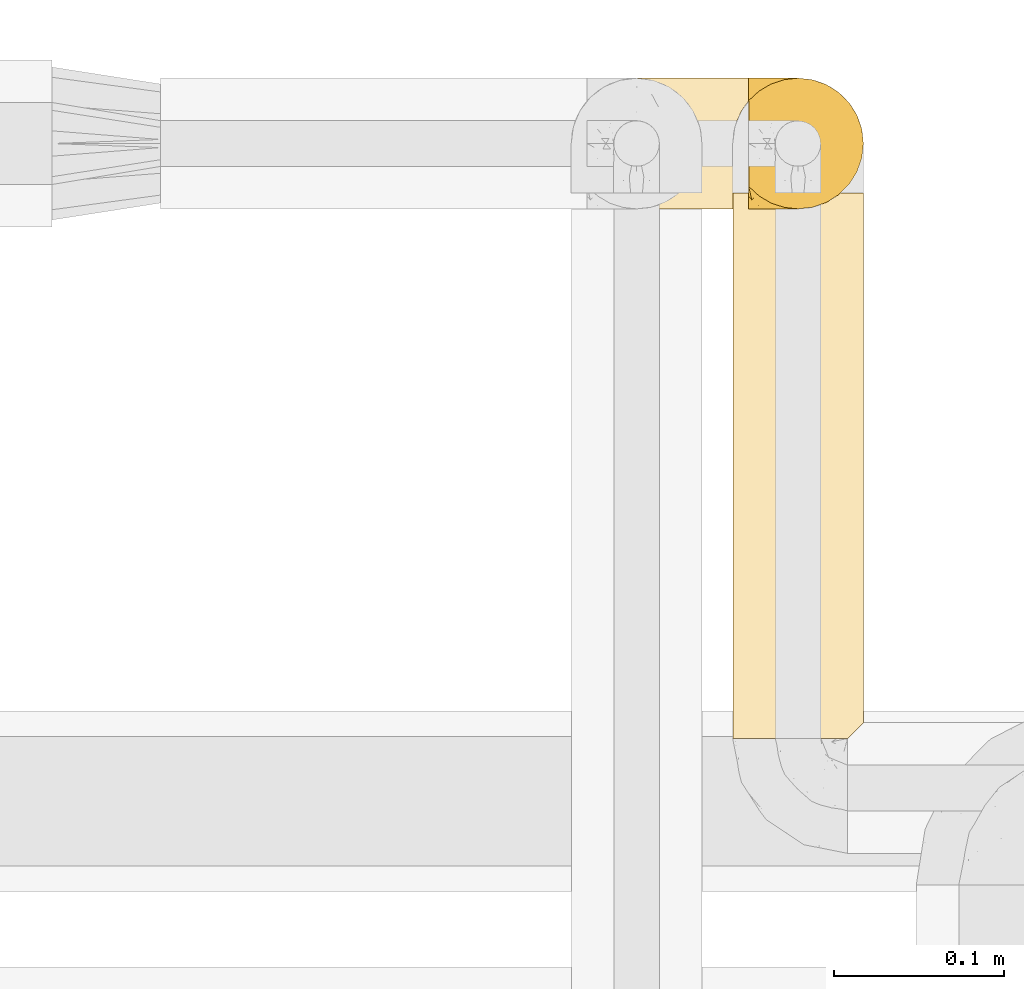
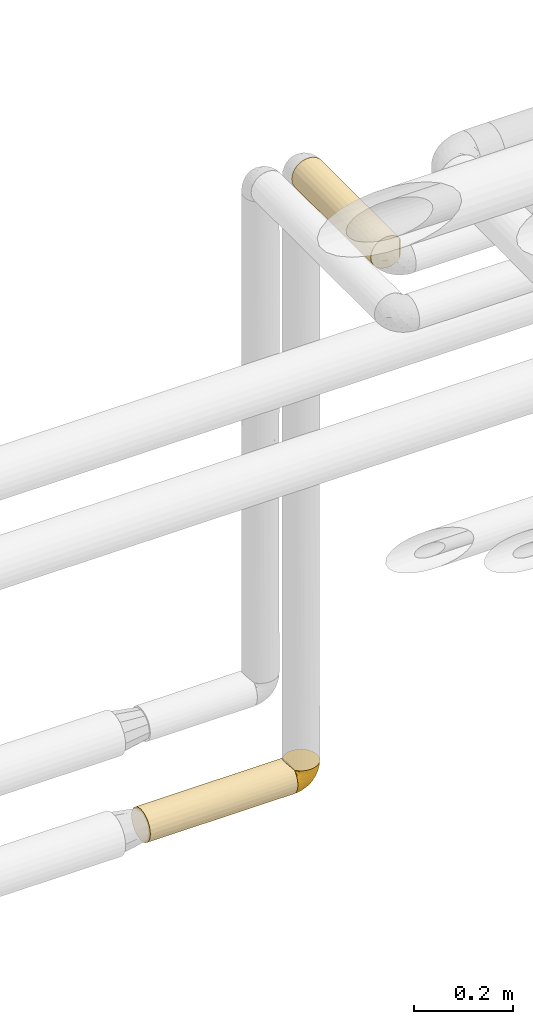
# One storey, part 367 of 827: 3 coverings.
"""IFC2X3 building model written with IfcOpenShell, lengths in millimetres."""

from ifc_helpers import new_model, entity, si_unit, converted_unit, derived_unit, direction, frame, origin, place, context, subcontext, project, spatial, faceted_brep, element, save


model = new_model("IFC2X3")

# Units and contexts
model_context = context("Model", 3, precision=0.01, world=origin(), true_north=direction((6.12303176911189e-17, 1.0)))
body_context = subcontext(model_context, "Body", "Model", "MODEL_VIEW")
ifc_project = project(units=[si_unit("LENGTHUNIT", "METRE", prefix="MILLI"), si_unit("AREAUNIT", "SQUARE_METRE"), si_unit("VOLUMEUNIT", "CUBIC_METRE"), converted_unit("PLANEANGLEUNIT", "DEGREE", entity("IfcRatioMeasure", 0.0174532925199433), si_unit("PLANEANGLEUNIT", "RADIAN"), dimensions=[0, 0, 0, 0, 0, 0, 0]), si_unit("MASSUNIT", "GRAM", prefix="KILO"), derived_unit("MASSDENSITYUNIT", [(si_unit("MASSUNIT", "GRAM", prefix="KILO"), 1), (si_unit("LENGTHUNIT", "METRE"), -3)]), derived_unit("MOMENTOFINERTIAUNIT", [(si_unit("LENGTHUNIT", "METRE"), 4)]), si_unit("TIMEUNIT", "SECOND"), si_unit("FREQUENCYUNIT", "HERTZ"), si_unit("THERMODYNAMICTEMPERATUREUNIT", "DEGREE_CELSIUS"), derived_unit("THERMALTRANSMITTANCEUNIT", [(si_unit("MASSUNIT", "GRAM", prefix="KILO"), 1), (si_unit("THERMODYNAMICTEMPERATUREUNIT", "KELVIN"), -1), (si_unit("TIMEUNIT", "SECOND"), -3)]), derived_unit("VOLUMETRICFLOWRATEUNIT", [(si_unit("LENGTHUNIT", "METRE"), 3), (si_unit("TIMEUNIT", "SECOND"), -1)]), derived_unit("MASSFLOWRATEUNIT", [(si_unit("MASSUNIT", "GRAM", prefix="KILO"), 1), (si_unit("TIMEUNIT", "SECOND"), -1)]), derived_unit("ROTATIONALFREQUENCYUNIT", [(si_unit("TIMEUNIT", "SECOND"), -1)]), si_unit("ELECTRICCURRENTUNIT", "AMPERE"), si_unit("ELECTRICVOLTAGEUNIT", "VOLT"), si_unit("POWERUNIT", "WATT"), si_unit("FORCEUNIT", "NEWTON", prefix="KILO"), si_unit("ILLUMINANCEUNIT", "LUX"), si_unit("LUMINOUSFLUXUNIT", "LUMEN"), si_unit("LUMINOUSINTENSITYUNIT", "CANDELA"), derived_unit("USERDEFINED", [(si_unit("MASSUNIT", "GRAM", prefix="KILO"), -1), (si_unit("LENGTHUNIT", "METRE"), -2), (si_unit("TIMEUNIT", "SECOND"), 3), (si_unit("LUMINOUSFLUXUNIT", "LUMEN"), 1)]), derived_unit("LINEARVELOCITYUNIT", [(si_unit("LENGTHUNIT", "METRE"), 1), (si_unit("TIMEUNIT", "SECOND"), -1)]), si_unit("PRESSUREUNIT", "PASCAL"), derived_unit("USERDEFINED", [(si_unit("LENGTHUNIT", "METRE"), -2), (si_unit("MASSUNIT", "GRAM", prefix="KILO"), 1), (si_unit("TIMEUNIT", "SECOND"), -2)]), derived_unit("LINEARFORCEUNIT", [(si_unit("MASSUNIT", "GRAM", prefix="KILO"), 1), (si_unit("LENGTHUNIT", "METRE"), 1), (si_unit("TIMEUNIT", "SECOND"), -2), (si_unit("LENGTHUNIT", "METRE"), -1)]), derived_unit("PLANARFORCEUNIT", [(si_unit("MASSUNIT", "GRAM", prefix="KILO"), 1), (si_unit("LENGTHUNIT", "METRE"), 1), (si_unit("TIMEUNIT", "SECOND"), -2), (si_unit("LENGTHUNIT", "METRE"), -2)])], contexts=[model_context])

# Site, building, storey
site_placement = place(None, origin())
site = spatial("IfcSite", under=ifc_project, at=site_placement, CompositionType="ELEMENT")
building_placement = place(site_placement, origin())
building = spatial("IfcBuilding", under=site, at=building_placement, CompositionType="ELEMENT")
storey_placement = place(building_placement, frame((0.0, 0.0, 28200.0)))
storey = spatial("IfcBuildingStorey", under=building, at=storey_placement, Name="08", CompositionType="ELEMENT", Elevation=28200.0)

# Coverings
covering_1_placement = place(storey_placement, frame((35975.02, 19454.61, 1660.0)))
element("IfcCovering", 1, at=covering_1_placement, inside=storey, Name=":ADSK_", ObjectType=":ADSK_", PredefinedType="INSULATION", context=body_context, shape_type="Brep", body=[
    faceted_brep([(345.9, 73.25, 20.8), (345.9, 77.09, 30.06), (345.9, 78.4, 40.0), (345.9, 77.51, 48.2), (345.9, 74.9, 56.01), (345.9, 70.68, 63.08), (345.9, 65.05, 69.1), (345.9, 14.94, 69.1), (345.9, 9.31, 63.08), (345.9, 5.09, 56.01), (345.9, 2.48, 48.2), (345.9, 1.6, 40.0), (345.9, 2.9, 30.06), (345.9, 6.74, 20.8), (345.9, 12.84, 12.84), (345.9, 20.8, 6.74), (345.9, 30.06, 2.9), (345.9, 40.0, 1.6), (345.9, 49.93, 2.9), (345.9, 59.2, 6.74), (345.9, 67.15, 12.84), (0.0, 78.4, 40.0), (0.0, 77.09, 30.06), (0.0, 73.25, 20.8), (0.0, 67.15, 12.84), (0.0, 59.2, 6.74), (0.0, 49.93, 2.9), (0.0, 40.0, 1.6), (0.0, 30.06, 2.9), (0.0, 20.8, 6.74), (0.0, 12.84, 12.84), (0.0, 6.74, 20.8), (0.0, 2.9, 30.06), (0.0, 1.6, 40.0), (0.0, 2.9, 49.93), (0.0, 6.74, 59.2), (0.0, 12.84, 67.15), (0.0, 20.8, 73.25), (0.0, 30.06, 77.09), (0.0, 40.0, 78.4), (0.0, 49.93, 77.09), (0.0, 59.2, 73.25), (0.0, 67.15, 67.15), (0.0, 73.25, 59.2), (0.0, 77.09, 49.93), (339.0, 53.36, 76.0), (337.2, 46.78, 77.79), (336.6, 40.0, 78.4), (341.93, 59.51, 73.07), (337.2, 33.21, 77.79), (339.0, 26.63, 76.0), (341.93, 20.48, 73.07)], [[[0, 1, 2, 3, 4, 5, 6, 7, 8, 9, 10, 11, 12, 13, 14, 15, 16, 17, 18, 19, 20]], [[21, 22, 23, 24, 25, 26, 27, 28, 29, 30, 31, 32, 33, 34, 35, 36, 37, 38, 39, 40, 41, 42, 43, 44]], [[32, 31, 13, 12]], [[33, 32, 12, 11]], [[14, 13, 31, 30]], [[16, 15, 29, 28]], [[17, 16, 28, 27]], [[30, 29, 15, 14]], [[18, 17, 27, 26]], [[19, 18, 26, 25]], [[25, 24, 20, 19]], [[1, 0, 23, 22]], [[2, 1, 22, 21]], [[24, 23, 0, 20]], [[3, 21, 44]], [[4, 44, 43]], [[5, 43, 42]], [[2, 21, 3]], [[3, 44, 4]], [[43, 5, 4]], [[42, 6, 5]], [[45, 41, 40]], [[40, 39, 46]], [[47, 46, 39]], [[48, 6, 41]], [[46, 45, 40]], [[48, 41, 45]], [[41, 6, 42]], [[49, 47, 39]], [[49, 39, 38]], [[50, 38, 37]], [[50, 49, 38]], [[7, 51, 37]], [[50, 37, 51]], [[37, 36, 7]], [[8, 36, 35]], [[9, 35, 34]], [[10, 34, 33]], [[8, 35, 9]], [[9, 34, 10]], [[33, 11, 10]], [[36, 8, 7]], [[46, 47, 49, 50, 51, 7, 6, 48, 45]]]),
])
covering_2_placement = place(storey_placement, frame((36319.33, 19454.56, 1659.95)))
element("IfcCovering", 2, at=covering_2_placement, inside=storey, Name=":ADSK_", ObjectType=":ADSK_", PredefinedType="INSULATION", context=body_context, shape_type="Brep", body=[
    faceted_brep([(47.38, 5.41, 69.15), (54.67, 9.99, 69.15), (60.76, 16.08, 69.15), (65.34, 23.37, 69.15), (68.18, 31.49, 69.15), (69.15, 40.05, 69.15), (68.18, 48.61, 69.15), (65.33, 56.73, 69.15), (60.75, 64.02, 69.15), (54.66, 70.11, 69.15), (47.37, 74.69, 69.15), (39.25, 77.53, 69.15), (30.7, 78.5, 69.15), (22.59, 77.63, 69.15), (14.86, 75.08, 69.15), (7.84, 70.97, 69.15), (1.85, 65.47, 69.15), (1.85, 63.27, 69.15), (1.85, 61.53, 69.15), (1.85, 59.57, 69.15), (1.85, 57.6, 69.15), (1.85, 55.63, 69.15), (1.85, 53.67, 69.15), (1.85, 51.7, 69.15), (1.85, 49.73, 69.15), (1.85, 47.54, 69.15), (1.85, 45.34, 69.15), (1.85, 43.15, 69.15), (1.85, 40.96, 69.15), (1.85, 38.76, 69.15), (1.85, 36.57, 69.15), (1.85, 34.37, 69.15), (1.85, 32.18, 69.15), (1.85, 29.98, 69.15), (1.85, 27.79, 69.15), (1.85, 25.6, 69.15), (1.85, 23.4, 69.15), (1.85, 21.21, 69.15), (1.85, 19.01, 69.15), (1.85, 16.82, 69.15), (1.85, 14.62, 69.15), (7.85, 9.12, 69.15), (14.88, 5.0, 69.15), (22.61, 2.46, 69.15), (30.7, 1.6, 69.15), (39.26, 2.56, 69.15), (1.6, 65.47, 68.89), (1.6, 70.97, 62.89), (1.6, 75.09, 55.87), (1.6, 77.63, 48.14), (1.6, 78.5, 40.05), (1.6, 77.19, 30.09), (1.6, 73.34, 20.82), (1.6, 67.23, 12.86), (1.6, 59.27, 6.75), (1.6, 50.0, 2.91), (1.6, 40.05, 1.6), (1.6, 30.09, 2.91), (1.6, 20.82, 6.75), (1.6, 12.86, 12.86), (1.6, 6.75, 20.82), (1.6, 2.91, 30.09), (1.6, 1.6, 40.05), (1.6, 2.46, 48.14), (1.6, 5.0, 55.87), (1.6, 9.12, 62.89), (1.6, 14.62, 68.89), (1.6, 16.82, 68.89), (1.6, 17.8, 68.89), (1.6, 19.39, 68.89), (1.6, 20.98, 68.89), (1.6, 22.57, 68.89), (1.6, 24.16, 68.89), (1.6, 25.75, 68.89), (1.6, 27.33, 68.89), (1.6, 28.92, 68.89), (1.6, 30.51, 68.89), (1.6, 32.1, 68.89), (1.6, 33.69, 68.89), (1.6, 35.28, 68.89), (1.6, 36.87, 68.89), (1.6, 38.46, 68.89), (1.6, 40.05, 68.89), (1.6, 41.63, 68.89), (1.6, 43.22, 68.89), (1.6, 44.81, 68.89), (1.6, 46.4, 68.89), (1.6, 47.99, 68.89), (1.6, 49.58, 68.89), (1.6, 51.17, 68.89), (1.6, 52.76, 68.89), (1.6, 54.72, 68.89), (1.6, 56.69, 68.89), (1.6, 58.88, 68.89), (1.6, 61.08, 68.89), (1.6, 63.27, 68.89), (1.78, 37.77, 68.97), (1.77, 36.07, 68.96), (1.78, 32.96, 68.97), (1.77, 31.36, 68.97), (1.79, 56.52, 68.98), (1.78, 54.96, 68.97), (1.76, 18.75, 68.96), (1.77, 58.07, 68.96), (1.77, 50.37, 68.96), (1.76, 23.36, 68.96), (1.77, 24.95, 68.96), (1.77, 42.43, 68.96), (1.8, 15.97, 69.0), (1.76, 51.96, 68.96), (1.77, 53.47, 68.96), (1.78, 48.63, 68.97), (1.77, 63.93, 68.96), (1.77, 40.93, 68.96), (1.76, 29.72, 68.96), (1.77, 62.4, 68.97), (1.78, 60.92, 68.97), (1.77, 17.31, 68.97), (1.77, 21.74, 68.96), (1.77, 34.56, 68.96), (1.78, 20.18, 68.97), (1.77, 14.62, 68.97), (1.8, 14.62, 69.02), (1.82, 14.62, 69.08), (1.77, 65.47, 68.97), (1.72, 65.47, 68.94), (1.66, 65.47, 68.92), (1.76, 59.5, 68.96), (1.77, 47.1, 68.96), (1.76, 45.61, 68.95), (1.77, 28.18, 68.96), (1.66, 14.62, 68.92), (1.72, 14.62, 68.94), (1.78, 26.61, 68.98), (1.82, 65.47, 69.08), (1.8, 65.47, 69.02), (1.77, 39.32, 68.96), (1.78, 44.12, 68.97), (3.72, 72.26, 61.33), (7.41, 76.57, 53.1), (6.13, 71.77, 63.33), (21.47, 78.5, 49.27), (19.34, 77.9, 55.53), (26.8, 78.5, 54.6), (8.87, 78.5, 41.99), (9.2, 75.52, 57.07), (12.79, 76.13, 57.95), (14.62, 77.81, 51.56), (7.34, 78.5, 41.58), (5.33, 72.4, 61.7), (17.64, 76.56, 63.33), (7.7, 71.77, 65.0), (9.41, 72.25, 67.02), (28.75, 78.5, 61.87), (16.15, 78.5, 43.94), (14.14, 75.75, 61.21), (29.16, 78.5, 63.4), (57.02, 50.46, 33.11), (64.92, 52.75, 52.82), (64.0, 40.05, 43.3), (11.92, 77.7, 33.73), (19.16, 77.66, 36.52), (28.65, 71.02, 24.87), (24.62, 63.45, 14.17), (15.19, 70.55, 18.43), (18.36, 75.57, 28.67), (9.2, 75.57, 26.0), (46.98, 72.61, 49.25), (50.24, 72.61, 59.72), (56.1, 67.24, 55.1), (28.97, 77.74, 44.72), (54.46, 57.43, 34.15), (21.34, 47.19, 5.25), (18.4, 54.76, 6.75), (66.44, 40.05, 55.54), (12.07, 63.45, 10.47), (45.49, 60.1, 25.49), (50.57, 63.72, 35.53), (36.04, 76.83, 48.22), (42.07, 76.34, 58.71), (62.12, 60.51, 57.42), (37.37, 72.59, 34.84), (29.39, 76.05, 36.87), (53.59, 66.15, 45.01), (58.06, 60.51, 44.4), (49.27, 51.88, 23.96), (29.63, 55.34, 11.2), (33.21, 48.67, 10.56), (40.1, 53.89, 16.81), (44.08, 46.73, 17.38), (49.36, 40.05, 21.38), (56.68, 40.05, 32.34), (15.2, 40.05, 4.3), (35.57, 63.95, 20.65), (41.7, 67.24, 29.66), (46.4, 69.62, 39.6), (41.41, 73.6, 42.55), (27.45, 40.05, 6.74), (38.4, 40.05, 14.06), (12.99, 4.52, 26.84), (21.33, 32.72, 5.28), (42.89, 27.18, 18.52), (57.04, 29.63, 33.13), (56.11, 12.86, 55.1), (62.13, 19.59, 57.43), (21.89, 9.54, 20.72), (16.62, 16.64, 11.46), (32.9, 17.48, 17.69), (46.99, 7.49, 49.26), (50.25, 7.49, 59.73), (42.08, 3.75, 58.71), (49.91, 20.75, 29.72), (15.6, 2.33, 35.35), (16.15, 1.6, 43.94), (8.87, 1.6, 41.99), (29.16, 1.6, 63.4), (13.16, 26.94, 4.93), (10.83, 9.54, 17.46), (33.8, 31.21, 10.94), (25.02, 25.33, 8.92), (64.92, 27.35, 52.83), (32.83, 8.17, 29.34), (20.56, 4.3, 30.26), (58.07, 19.59, 44.4), (21.46, 2.23, 39.06), (28.1, 2.45, 43.06), (26.8, 1.6, 54.6), (21.47, 1.6, 49.27), (51.29, 12.86, 42.69), (36.04, 3.27, 48.2), (28.75, 1.6, 61.87), (8.45, 2.29, 33.44), (41.73, 12.86, 29.67), (39.27, 6.89, 38.5), (33.56, 12.43, 23.35), (27.29, 4.1, 34.97), (7.41, 3.53, 53.1), (3.51, 6.88, 59.68), (4.68, 8.16, 62.19), (5.52, 9.02, 64.11), (8.75, 5.0, 57.97), (12.79, 3.96, 57.95), (17.65, 3.52, 63.33), (13.9, 2.4, 51.77), (9.42, 7.83, 67.02), (7.68, 8.32, 64.98), (19.33, 2.19, 55.53), (14.13, 4.34, 61.22)], [[[0, 1, 2, 3, 4, 5, 6, 7, 8, 9, 10, 11, 12, 13, 14, 15, 16, 17, 18, 19, 20, 21, 22, 23, 24, 25, 26, 27, 28, 29, 30, 31, 32, 33, 34, 35, 36, 37, 38, 39, 40, 41, 42, 43, 44, 45]], [[46, 47, 48, 49, 50, 51, 52, 53, 54, 55, 56, 57, 58, 59, 60, 61, 62, 63, 64, 65, 66, 67, 68, 69, 70, 71, 72, 73, 74, 75, 76, 77, 78, 79, 80, 81, 82, 83, 84, 85, 86, 87, 88, 89, 90, 91, 92, 93, 94, 95]], [[96, 97, 30]], [[98, 77, 99]], [[100, 101, 21]], [[69, 68, 102]], [[20, 19, 103]], [[24, 23, 104]], [[20, 103, 100]], [[72, 105, 106]], [[84, 83, 107]], [[89, 88, 104]], [[108, 67, 66]], [[109, 110, 90]], [[111, 25, 24]], [[112, 17, 16]], [[82, 113, 83]], [[109, 23, 22]], [[114, 76, 75]], [[105, 36, 106]], [[104, 111, 24]], [[18, 115, 116]], [[97, 96, 80]], [[67, 108, 117]], [[105, 71, 118]], [[31, 97, 119]], [[102, 120, 69]], [[108, 121, 122, 123, 40]], [[112, 95, 115]], [[17, 115, 18]], [[94, 116, 115]], [[117, 68, 67]], [[38, 117, 39]], [[112, 124, 125, 126, 46]], [[17, 112, 115]], [[70, 120, 118]], [[39, 117, 108]], [[120, 38, 37]], [[120, 37, 118]], [[120, 70, 69]], [[116, 94, 127]], [[128, 86, 129]], [[117, 38, 102]], [[74, 130, 75]], [[99, 33, 32]], [[115, 95, 94]], [[39, 108, 40]], [[108, 66, 131, 132, 121]], [[105, 72, 71]], [[118, 37, 36]], [[71, 70, 118]], [[35, 106, 36]], [[36, 105, 118]], [[35, 133, 106]], [[74, 73, 133]], [[106, 133, 73]], [[99, 114, 33]], [[133, 35, 34]], [[73, 72, 106]], [[95, 112, 46]], [[112, 16, 134, 135, 124]], [[130, 114, 75]], [[99, 76, 114]], [[114, 130, 33]], [[34, 33, 130]], [[78, 77, 98]], [[98, 119, 78]], [[130, 133, 34]], [[133, 130, 74]], [[79, 97, 80]], [[98, 99, 32]], [[98, 32, 31]], [[77, 76, 99]], [[97, 79, 119]], [[136, 96, 29]], [[30, 97, 31]], [[136, 29, 28]], [[81, 80, 96]], [[29, 96, 30]], [[31, 119, 98]], [[119, 79, 78]], [[96, 136, 81]], [[82, 81, 136]], [[113, 107, 83]], [[84, 107, 137]], [[107, 27, 137]], [[113, 28, 107]], [[27, 107, 28]], [[85, 84, 137]], [[137, 27, 26]], [[113, 136, 28]], [[136, 113, 82]], [[109, 89, 104]], [[86, 85, 129]], [[89, 109, 90]], [[111, 87, 128]], [[26, 129, 137]], [[88, 111, 104]], [[25, 111, 128]], [[22, 110, 109]], [[23, 109, 104]], [[110, 91, 90]], [[100, 92, 101]], [[110, 22, 101]], [[91, 110, 101]], [[116, 19, 18]], [[111, 88, 87]], [[127, 103, 19]], [[25, 128, 26]], [[86, 128, 87]], [[128, 129, 26]], [[137, 129, 85]], [[120, 102, 38]], [[117, 102, 68]], [[91, 101, 92]], [[21, 101, 22]], [[93, 92, 103]], [[100, 21, 20]], [[100, 103, 92]], [[127, 93, 103]], [[93, 127, 94]], [[116, 127, 19]], [[126, 138, 47]], [[48, 138, 139]], [[140, 125, 124]], [[141, 142, 143]], [[144, 49, 139]], [[145, 140, 146]], [[48, 139, 49]], [[139, 145, 147]], [[49, 144, 148, 50]], [[126, 125, 149]], [[14, 13, 150]], [[151, 146, 140]], [[149, 140, 145]], [[152, 151, 135]], [[152, 14, 150]], [[16, 15, 134]], [[13, 153, 150]], [[124, 151, 140]], [[141, 147, 142]], [[14, 152, 15]], [[15, 152, 134]], [[47, 46, 126]], [[139, 154, 144]], [[138, 48, 47]], [[125, 140, 149]], [[135, 134, 152]], [[146, 155, 142]], [[145, 146, 147]], [[149, 139, 138]], [[147, 141, 154]], [[147, 146, 142]], [[139, 147, 154]], [[139, 149, 145]], [[149, 138, 126]], [[155, 146, 151]], [[150, 143, 142]], [[152, 155, 151]], [[150, 142, 155]], [[13, 12, 156, 153]], [[153, 143, 150]], [[152, 150, 155]], [[151, 124, 135]], [[157, 158, 159]], [[160, 154, 161]], [[162, 163, 164]], [[165, 166, 160]], [[167, 168, 169]], [[141, 170, 161]], [[156, 12, 11]], [[158, 157, 171]], [[172, 55, 173]], [[158, 6, 174]], [[175, 54, 53]], [[52, 166, 164]], [[52, 164, 53]], [[54, 175, 173]], [[166, 52, 51]], [[176, 177, 171]], [[178, 143, 179]], [[156, 11, 179]], [[8, 7, 180]], [[169, 9, 8]], [[179, 143, 153, 156]], [[179, 11, 10]], [[168, 179, 10]], [[181, 162, 182]], [[179, 167, 178]], [[183, 184, 177]], [[183, 169, 184]], [[176, 171, 185]], [[172, 186, 187]], [[158, 7, 6]], [[159, 158, 174]], [[184, 180, 158]], [[54, 173, 55]], [[180, 169, 8]], [[188, 189, 187]], [[9, 168, 10]], [[186, 188, 187]], [[190, 157, 159, 191]], [[55, 172, 192]], [[176, 193, 194]], [[161, 170, 182]], [[162, 164, 165]], [[175, 164, 163]], [[51, 50, 148]], [[167, 195, 196]], [[178, 182, 170]], [[6, 5, 174]], [[158, 180, 7]], [[169, 180, 184]], [[169, 168, 9]], [[179, 168, 167]], [[182, 162, 165]], [[162, 194, 193]], [[161, 165, 160]], [[195, 181, 196]], [[192, 172, 197]], [[192, 56, 55]], [[189, 190, 198]], [[198, 197, 187]], [[172, 187, 197]], [[185, 189, 188]], [[198, 187, 189]], [[186, 172, 173]], [[173, 163, 186]], [[193, 186, 163]], [[176, 185, 188]], [[185, 157, 190]], [[188, 186, 193]], [[177, 176, 194]], [[188, 193, 176]], [[162, 193, 163]], [[195, 177, 194]], [[171, 177, 184]], [[181, 195, 194]], [[183, 167, 169]], [[162, 181, 194]], [[196, 182, 178]], [[158, 171, 184]], [[171, 157, 185]], [[177, 195, 183]], [[167, 183, 195]], [[182, 196, 181]], [[178, 170, 143]], [[178, 167, 196]], [[164, 175, 53]], [[173, 175, 163]], [[160, 51, 148]], [[164, 166, 165]], [[51, 160, 166]], [[160, 148, 144, 154]], [[141, 161, 154]], [[182, 165, 161]], [[190, 189, 185]], [[143, 170, 141]], [[60, 199, 61]], [[197, 200, 192]], [[201, 190, 202]], [[200, 57, 192]], [[203, 204, 2]], [[205, 206, 207]], [[208, 209, 210]], [[211, 207, 201]], [[212, 213, 214]], [[45, 215, 210]], [[216, 206, 58]], [[45, 44, 215]], [[59, 217, 60]], [[60, 217, 199]], [[0, 45, 210]], [[218, 201, 219]], [[202, 159, 220]], [[205, 221, 222]], [[223, 204, 203]], [[1, 203, 2]], [[57, 200, 216]], [[220, 3, 204]], [[220, 174, 4]], [[1, 0, 209]], [[212, 224, 213]], [[225, 226, 227]], [[228, 223, 203]], [[208, 210, 229]], [[210, 226, 229]], [[3, 220, 4]], [[58, 206, 59]], [[209, 203, 1]], [[202, 220, 223]], [[228, 203, 208]], [[202, 211, 201]], [[3, 2, 204]], [[202, 190, 191, 159]], [[210, 215, 230, 226]], [[199, 212, 231]], [[232, 233, 221]], [[233, 208, 229]], [[207, 206, 219]], [[217, 206, 205]], [[227, 224, 225]], [[233, 232, 228]], [[201, 207, 219]], [[234, 232, 221]], [[218, 219, 200]], [[202, 223, 211]], [[174, 220, 159]], [[174, 5, 4]], [[61, 231, 62]], [[220, 204, 223]], [[210, 209, 0]], [[203, 209, 208]], [[225, 233, 229]], [[224, 227, 213]], [[221, 233, 235]], [[57, 56, 192]], [[198, 218, 197]], [[200, 219, 216]], [[201, 198, 190]], [[197, 218, 200]], [[198, 201, 218]], [[206, 216, 219]], [[58, 57, 216]], [[231, 212, 214]], [[222, 212, 199]], [[228, 211, 223]], [[207, 211, 232]], [[62, 231, 214]], [[199, 231, 61]], [[233, 228, 208]], [[211, 228, 232]], [[222, 221, 235]], [[234, 205, 207]], [[206, 217, 59]], [[199, 217, 205]], [[205, 222, 199]], [[224, 222, 235]], [[222, 224, 212]], [[224, 235, 225]], [[233, 225, 235]], [[226, 225, 229]], [[205, 234, 221]], [[207, 232, 234]], [[63, 214, 236]], [[214, 213, 236]], [[214, 63, 62]], [[237, 236, 238]], [[238, 132, 131]], [[236, 237, 64]], [[239, 240, 241]], [[63, 236, 64]], [[131, 66, 65]], [[237, 131, 65]], [[242, 230, 43]], [[237, 65, 64]], [[239, 121, 132]], [[42, 242, 43]], [[241, 240, 243]], [[41, 123, 244]], [[43, 230, 215, 44]], [[244, 122, 245]], [[227, 246, 243]], [[241, 247, 245]], [[121, 239, 245]], [[41, 40, 123]], [[132, 238, 239]], [[244, 42, 41]], [[131, 237, 238]], [[240, 239, 238]], [[245, 239, 241]], [[247, 241, 246]], [[247, 244, 245]], [[238, 236, 240]], [[243, 236, 213]], [[236, 243, 240]], [[227, 226, 246]], [[243, 213, 227]], [[242, 246, 226]], [[243, 246, 241]], [[246, 242, 247]], [[244, 247, 242]], [[242, 226, 230]], [[42, 244, 242]], [[122, 244, 123]], [[122, 121, 245]]]),
])
covering_3_placement = place(storey_placement, frame((36310.03, 19142.99, 3160.0)))
element("IfcCovering", 3, at=covering_3_placement, inside=storey, Name=":ADSK_", ObjectType=":ADSK_", PredefinedType="INSULATION", context=body_context, shape_type="Brep", body=[
    faceted_brep([(20.8, 322.51, 73.25), (30.06, 322.51, 77.09), (40.0, 322.51, 78.4), (49.93, 322.51, 77.09), (59.2, 322.51, 73.25), (67.15, 322.51, 67.15), (73.25, 322.51, 59.2), (77.09, 322.51, 49.93), (78.4, 322.51, 40.0), (77.51, 322.51, 31.79), (74.9, 322.51, 23.98), (70.68, 322.51, 16.91), (65.05, 322.51, 10.9), (14.94, 322.51, 10.9), (9.31, 322.51, 16.91), (5.09, 322.51, 23.98), (2.48, 322.51, 31.79), (1.6, 322.51, 40.0), (2.9, 322.51, 49.93), (6.74, 322.51, 59.2), (12.84, 322.51, 67.15), (40.0, 1.6, 78.4), (30.06, 1.6, 77.09), (20.8, 1.6, 73.25), (12.84, 1.6, 67.15), (6.74, 1.6, 59.2), (2.9, 1.6, 49.93), (1.6, 1.6, 40.0), (2.9, 1.6, 30.06), (6.74, 1.6, 20.8), (12.84, 1.6, 12.84), (20.8, 1.6, 6.74), (30.06, 1.6, 2.9), (40.0, 1.6, 1.6), (48.2, 1.6, 2.48), (56.01, 1.6, 5.09), (63.08, 1.6, 9.31), (69.1, 1.6, 14.94), (69.1, 1.6, 65.05), (63.08, 1.6, 70.68), (56.01, 1.6, 74.9), (48.2, 1.6, 77.51), (77.79, 10.29, 33.21), (76.0, 8.5, 26.63), (73.07, 5.57, 20.48), (78.4, 10.9, 40.0), (59.51, 318.54, 6.92), (53.36, 315.61, 4.0), (46.78, 313.82, 2.2), (40.0, 313.21, 1.6), (33.21, 313.82, 2.2), (26.63, 315.61, 4.0), (20.48, 318.54, 6.92), (73.07, 5.57, 59.51), (76.0, 8.5, 53.36), (77.79, 10.29, 46.78)], [[[0, 1, 2, 3, 4, 5, 6, 7, 8, 9, 10, 11, 12, 13, 14, 15, 16, 17, 18, 19, 20]], [[21, 22, 23, 24, 25, 26, 27, 28, 29, 30, 31, 32, 33, 34, 35, 36, 37, 38, 39, 40, 41]], [[42, 43, 9]], [[44, 37, 11]], [[43, 44, 10]], [[45, 42, 8]], [[9, 8, 42]], [[43, 10, 9]], [[44, 11, 10]], [[37, 12, 11]], [[46, 36, 35]], [[47, 35, 34]], [[48, 34, 33]], [[46, 12, 36]], [[48, 47, 34]], [[49, 48, 33]], [[46, 35, 47]], [[36, 12, 37]], [[50, 49, 33]], [[50, 33, 32]], [[51, 32, 31]], [[51, 50, 32]], [[13, 52, 31]], [[51, 31, 52]], [[31, 30, 13]], [[14, 30, 29]], [[15, 29, 28]], [[16, 28, 27]], [[14, 29, 15]], [[15, 28, 16]], [[27, 17, 16]], [[30, 14, 13]], [[18, 17, 27, 26]], [[19, 18, 26, 25]], [[25, 24, 20, 19]], [[1, 0, 23, 22]], [[2, 1, 22, 21]], [[24, 23, 0, 20]], [[2, 21, 41]], [[3, 41, 40]], [[4, 40, 39]], [[2, 41, 3]], [[3, 40, 4]], [[39, 5, 4]], [[39, 38, 5]], [[38, 53, 6]], [[54, 55, 7]], [[53, 54, 6]], [[6, 54, 7]], [[8, 7, 55]], [[45, 8, 55]], [[38, 6, 5]], [[47, 48, 49, 50, 51, 52, 13, 12, 46]], [[37, 44, 43, 42, 45, 55, 54, 53, 38]]]),
])

save(model, "model.ifc")
